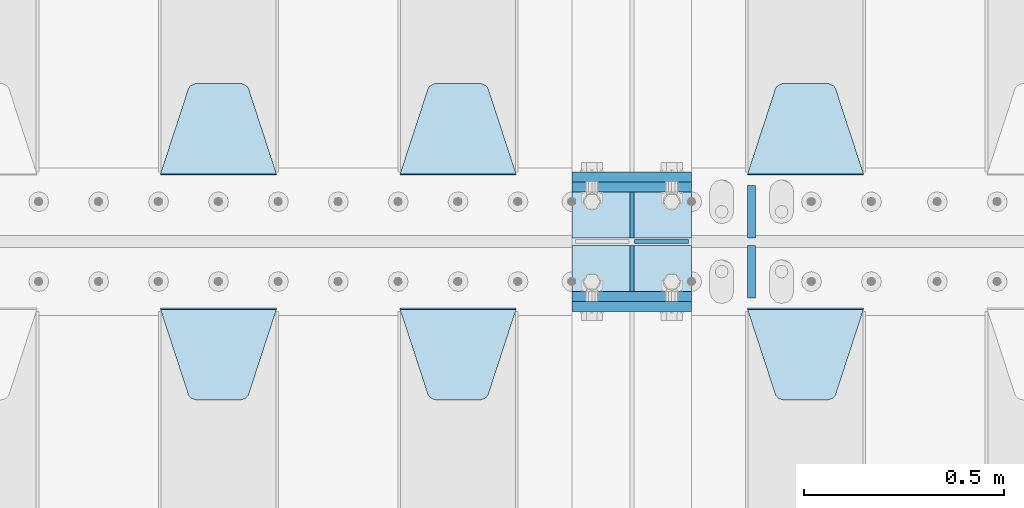
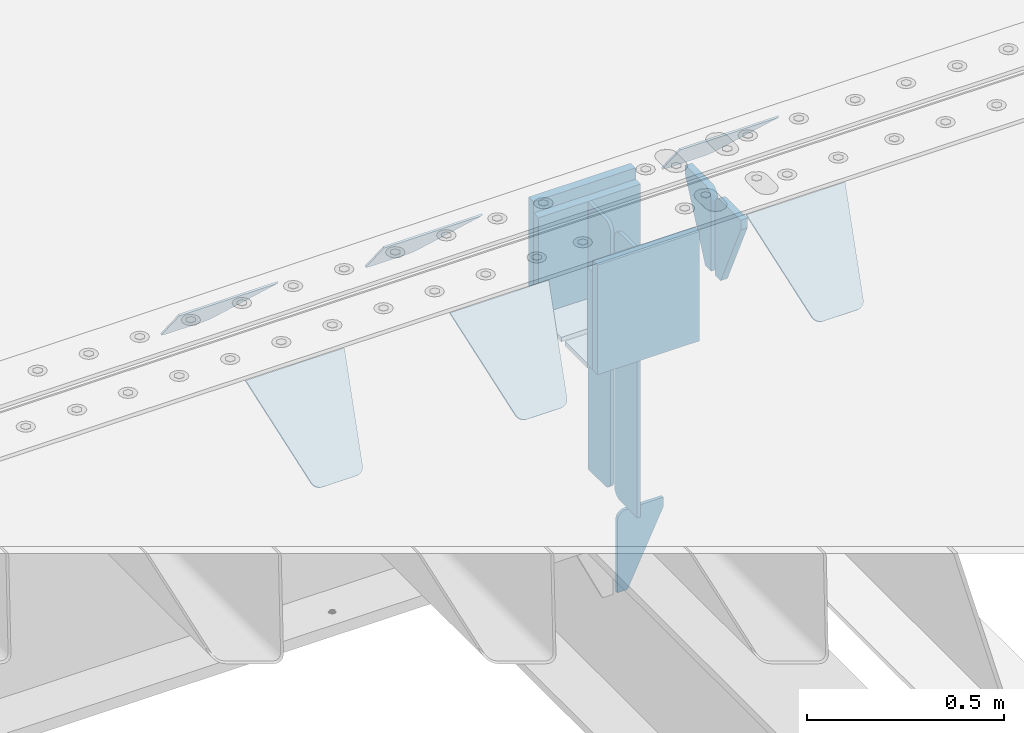
# One storey, part 228 of 270: 19 plates.
"""IFC2X3 building model written with IfcOpenShell, lengths in millimetres."""

from ifc_helpers import new_model, si_unit, frame, origin_with_axes, place, context, subcontext, project, spatial, faceted_brep, material, type_object, element, save


model = new_model("IFC2X3")

# Units and contexts
model_context = context("Model", 3, precision=1e-05, world=origin_with_axes())
body_context = subcontext(model_context, "Body", "Model", "MODEL_VIEW")
ifc_project = project(units=[si_unit("LENGTHUNIT", "METRE", prefix="MILLI"), si_unit("AREAUNIT", "SQUARE_METRE"), si_unit("VOLUMEUNIT", "CUBIC_METRE"), si_unit("MASSUNIT", "GRAM", prefix="KILO"), si_unit("TIMEUNIT", "SECOND"), si_unit("PLANEANGLEUNIT", "RADIAN"), si_unit("SOLIDANGLEUNIT", "STERADIAN"), si_unit("THERMODYNAMICTEMPERATUREUNIT", "DEGREE_CELSIUS"), si_unit("LUMINOUSINTENSITYUNIT", "LUMEN")], contexts=[model_context])

# Site, building, storey
site_placement = place(None, origin_with_axes())
site = spatial("IfcSite", under=ifc_project, at=site_placement, CompositionType="ELEMENT")
building_placement = place(site_placement, origin_with_axes())
building = spatial("IfcBuilding", under=site, at=building_placement, Name="Standard", CompositionType="ELEMENT")
storey_placement = place(building_placement, origin_with_axes())
storey = spatial("IfcBuildingStorey", under=building, at=storey_placement, Name="Undefined", CompositionType="ELEMENT", Elevation=0.0)

# Plates
ifc_material = material(Name="STEEL/S355N")
plate_type_1 = type_object("IfcPlateType", PredefinedType="NOTDEFINED")
for number, where, z_axis, x_axis in (
    (1, (13885.0, -17837.5, -340.000000000044), (0.0, 0.0, 1.0), (1.0, 0.0, 0.0)),
    (2, (13885.0, -18162.5, -340.000000000044), (0.0, 0.0, 1.0), (1.0, 0.0, 0.0)),
):
    element("IfcPlate", number, at=place(storey_placement, frame(where, z_axis=z_axis, x_axis=x_axis)), inside=storey, type_object=plate_type_1, material=ifc_material, context=body_context, shape_type="Brep", body=[
        faceted_brep([(0.0, -12.5, 0.0), (9.27684595808387e-10, -12.5, 340.0), (9.27684595808387e-10, 12.5, 340.0), (0.0, 12.5, 0.0), (300.0, -12.5, 340.0), (300.0, 12.5, 340.0), (300.0, -12.5, 0.0), (300.0, 12.5, 0.0)], [[[0, 1, 2, 3]], [[1, 4, 5, 2]], [[4, 6, 7, 5]], [[6, 0, 3, 7]], [[5, 7, 3, 2]], [[6, 4, 1, 0]]]),
    ])
for number, where, z_axis, x_axis in (
    (3, (13885.0, -17862.5, -340.0), (0.0, 0.0, 1.0), (1.0, 0.0, 0.0)),
    (4, (13885.0, -18137.5, -340.0), (0.0, 0.0, 1.0), (1.0, 0.0, 0.0)),
):
    element("IfcPlate", number, at=place(storey_placement, frame(where, z_axis=z_axis, x_axis=x_axis)), inside=storey, type_object=plate_type_1, material=ifc_material, context=body_context, shape_type="Brep", body=[
        faceted_brep([(0.0, -12.5, 0.0), (0.0, -12.5, 305.0), (0.0, 12.5, 305.0), (0.0, 12.5, 0.0), (300.0, -12.5, 305.0), (300.0, 12.5, 305.0), (300.0, -12.5, 0.0), (300.0, 12.5, 0.0)], [[[0, 1, 2, 3]], [[1, 4, 5, 2]], [[4, 6, 7, 5]], [[6, 0, 3, 7]], [[5, 7, 3, 2]], [[6, 4, 1, 0]]]),
    ])
plate_type_2 = type_object("IfcPlateType", PredefinedType="NOTDEFINED")
for number, where, z_axis, x_axis in (
    (5, (13885.0, -18009.25, -343.0), (0.0, -1.0, 0.0), (1.0, 0.0, 0.0)),
    (6, (13885.0, -17990.75, -343.0), (0.0, 1.0, 0.0), (1.0, 0.0, 0.0)),
):
    element("IfcPlate", number, at=place(storey_placement, frame(where, z_axis=z_axis, x_axis=x_axis)), inside=storey, type_object=plate_type_2, material=ifc_material, context=body_context, shape_type="Brep", body=[
        faceted_brep([(0.0, -7.0, 0.0), (0.0, -7.0, 115.75), (0.0, 7.0, 115.75), (0.0, 7.0, 0.0), (300.0, -7.0, 115.75), (300.0, 7.0, 115.75), (300.0, -7.0, 0.0), (300.0, 7.0, 0.0)], [[[0, 1, 2, 3]], [[1, 4, 5, 2]], [[4, 6, 7, 5]], [[6, 0, 3, 7]], [[5, 7, 3, 2]], [[6, 4, 1, 0]]]),
    ])
plate_type_3 = type_object("IfcPlateType", PredefinedType="NOTDEFINED")
plate_1_placement = place(storey_placement, frame((14035.0, -17990.75, -35.0), z_axis=(0.0, 0.0, -1.0), x_axis=(0.0, 1.0, 0.0)))
element("IfcPlate", 7, at=plate_1_placement, inside=storey, type_object=plate_type_3, material=ifc_material, context=body_context, shape_type="Brep", body=[
    faceted_brep([(0.0, -5.0, 30.0), (0.0, -5.0, 301.0), (0.0, 5.0, 301.0), (0.0, 5.0, 30.0), (115.75, -5.0, 301.0), (115.75, 5.0, 301.0), (115.75, -5.0, 0.0), (115.75, 5.0, 0.0), (30.0, -5.0, 0.0), (30.0, 5.0, 0.0), (24.7905546699913, -5.0, 0.455767409633758), (24.7905546699913, 5.0, 0.455767409633758), (19.7393957002314, -5.0, 1.80922137642275), (19.7393957002314, 5.0, 1.80922137642275), (15.0, -5.0, 4.01923788646684), (15.0, 5.0, 4.01923788646684), (10.7163717094045, -5.0, 7.01866670643066), (10.7163717094045, 5.0, 7.01866670643066), (7.01866670642994, -5.0, 10.7163717094038), (7.01866670642994, 5.0, 10.7163717094038), (4.01923788646673, -5.0, 15.0), (4.01923788646673, 5.0, 15.0), (1.80922137642119, -5.0, 19.7393957002299), (1.80922137642119, 5.0, 19.7393957002299), (0.455767409632244, -5.0, 24.7905546699921), (0.455767409632244, 5.0, 24.7905546699921)], [[[0, 1, 2, 3]], [[1, 4, 5, 2]], [[4, 6, 7, 5]], [[6, 8, 9, 7]], [[8, 10, 11, 9]], [[10, 12, 13, 11]], [[12, 14, 15, 13]], [[14, 16, 17, 15]], [[16, 18, 19, 17]], [[18, 20, 21, 19]], [[20, 22, 23, 21]], [[22, 24, 25, 23]], [[24, 0, 3, 25]], [[5, 7, 9, 11, 13, 15, 17, 19, 21, 23, 25, 3, 2]], [[24, 22, 20, 18, 16, 14, 12, 10, 8, 6, 4, 1, 0]]]),
])
for number, where, z_axis, x_axis in (
    (8, (14035.0, -18009.25, -350.0), (0.0, 0.0, -1.0), (0.0, -1.0, 0.0)),
    (9, (14035.0, -17990.75, -350.0), (0.0, 0.0, -1.0), (0.0, 1.0, 0.0)),
):
    element("IfcPlate", number, at=place(storey_placement, frame(where, z_axis=z_axis, x_axis=x_axis)), inside=storey, type_object=plate_type_3, material=ifc_material, context=body_context, shape_type="Brep", body=[
        faceted_brep([(0.0, -5.0, 0.0), (0.0, -5.0, 485.0), (0.0, 5.0, 485.0), (0.0, 5.0, 0.0), (0.455767409634063, -5.0, 490.209445330008), (0.455767409634063, 5.0, 490.209445330008), (1.80922137642301, -5.0, 495.26060429977), (1.80922137642301, 5.0, 495.26060429977), (4.01923788646673, -5.0, 500.0), (4.01923788646673, 5.0, 500.0), (7.01866670642994, -5.0, 504.283628290596), (7.01866670642994, 5.0, 504.283628290596), (10.7163717094045, -5.0, 507.981333293569), (10.7163717094045, 5.0, 507.981333293569), (15.0, -5.0, 510.980762113533), (15.0, 5.0, 510.980762113533), (19.7393957002296, -5.0, 513.190778623577), (19.7393957002296, 5.0, 513.190778623577), (24.7905546699913, -5.0, 514.544232590366), (24.7905546699913, 5.0, 514.544232590366), (30.0, -5.0, 515.0), (30.0, 5.0, 515.0), (115.75, -5.0, 515.0), (115.75, 5.0, 515.0), (115.75, -5.0, 0.0), (115.75, 5.0, 0.0)], [[[0, 1, 2, 3]], [[1, 4, 5, 2]], [[4, 6, 7, 5]], [[6, 8, 9, 7]], [[8, 10, 11, 9]], [[10, 12, 13, 11]], [[12, 14, 15, 13]], [[14, 16, 17, 15]], [[16, 18, 19, 17]], [[18, 20, 21, 19]], [[20, 22, 23, 21]], [[22, 24, 25, 23]], [[24, 0, 3, 25]], [[5, 7, 9, 11, 13, 15, 17, 19, 21, 23, 25, 3, 2]], [[24, 22, 20, 18, 16, 14, 12, 10, 8, 6, 4, 1, 0]]]),
    ])
plate_2_placement = place(storey_placement, frame((14035.0, -18009.25, -35.0), z_axis=(0.0, 0.0, -1.0), x_axis=(0.0, -1.0, 0.0)))
element("IfcPlate", 10, at=plate_2_placement, inside=storey, type_object=plate_type_3, material=ifc_material, context=body_context, shape_type="Brep", body=[
    faceted_brep([(0.0, -5.0, 30.0), (0.0, -5.0, 301.0), (0.0, 5.0, 301.0), (0.0, 5.0, 30.0), (115.75, -5.0, 301.0), (115.75, 5.0, 301.0), (115.75, -5.0, 0.0), (115.75, 5.0, 0.0), (30.0, -5.0, 0.0), (30.0, 5.0, 0.0), (24.7905546699913, -5.0, 0.455767409633758), (24.7905546699913, 5.0, 0.455767409633758), (19.7393957002314, -5.0, 1.80922137642275), (19.7393957002314, 5.0, 1.80922137642275), (15.0, -5.0, 4.01923788646684), (15.0, 5.0, 4.01923788646684), (10.7163717094045, -5.0, 7.01866670643066), (10.7163717094045, 5.0, 7.01866670643066), (7.01866670642994, -5.0, 10.7163717094038), (7.01866670642994, 5.0, 10.7163717094038), (4.01923788646673, -5.0, 15.0), (4.01923788646673, 5.0, 15.0), (1.80922137642119, -5.0, 19.7393957002299), (1.80922137642119, 5.0, 19.7393957002299), (0.455767409632244, -5.0, 24.7905546699921), (0.455767409632244, 5.0, 24.7905546699921)], [[[0, 1, 2, 3]], [[1, 4, 5, 2]], [[4, 6, 7, 5]], [[6, 8, 9, 7]], [[8, 10, 11, 9]], [[10, 12, 13, 11]], [[12, 14, 15, 13]], [[14, 16, 17, 15]], [[16, 18, 19, 17]], [[18, 20, 21, 19]], [[20, 22, 23, 21]], [[22, 24, 25, 23]], [[24, 0, 3, 25]], [[5, 7, 9, 11, 13, 15, 17, 19, 21, 23, 25, 3, 2]], [[24, 22, 20, 18, 16, 14, 12, 10, 8, 6, 4, 1, 0]]]),
])
plate_type_4 = type_object("IfcPlateType", PredefinedType="NOTDEFINED")
plate_3_placement = place(storey_placement, frame((14041.5000000039, -18000.0000000457, -925.000018238937), z_axis=(0.0, 0.0, -1.0), x_axis=(1.0, 0.0, 0.0)))
element("IfcPlate", 11, at=plate_3_placement, inside=storey, type_object=plate_type_4, material=ifc_material, context=body_context, shape_type="Brep", body=[
    faceted_brep([(0.0, -5.0, 27.0), (0.0, -5.0, 250.0), (0.0, 5.0, 250.0), (0.0, 5.0, 27.0), (30.0, -5.0, 250.0), (30.0, 5.0, 250.0), (135.0, -5.0, 30.0), (135.0, 5.0, 30.0), (135.0, -5.0, 0.0), (135.0, 5.0, 0.0), (27.0, -5.0, 0.0), (27.0, 5.0, 0.0), (22.3114992029932, -5.0, 0.410190668670339), (22.3114992029932, 5.0, 0.410190668670339), (17.7654561302061, -5.0, 1.62829923878053), (17.7654561302061, 5.0, 1.62829923878053), (13.5, -5.0, 3.6173140978201), (13.5, 5.0, 3.6173140978201), (9.64473453846404, -5.0, 6.31680003578754), (9.64473453846404, 5.0, 6.31680003578754), (6.31680003578731, -5.0, 9.64473453846347), (6.31680003578731, 5.0, 9.64473453846347), (3.61731409782078, -5.0, 13.5), (3.61731409782078, 5.0, 13.5), (1.62829923878053, -5.0, 17.765456130207), (1.62829923878053, 5.0, 17.765456130207), (0.410190668670111, -5.0, 22.3114992029929), (0.410190668670111, 5.0, 22.3114992029929)], [[[0, 1, 2, 3]], [[1, 4, 5, 2]], [[4, 6, 7, 5]], [[6, 8, 9, 7]], [[8, 10, 11, 9]], [[10, 12, 13, 11]], [[12, 14, 15, 13]], [[14, 16, 17, 15]], [[16, 18, 19, 17]], [[18, 20, 21, 19]], [[20, 22, 23, 21]], [[22, 24, 25, 23]], [[24, 26, 27, 25]], [[26, 0, 3, 27]], [[5, 7, 9, 11, 13, 15, 17, 19, 21, 23, 25, 27, 3, 2]], [[26, 24, 22, 20, 18, 16, 14, 12, 10, 8, 6, 4, 1, 0]]]),
])
plate_type_5 = type_object("IfcPlateType", PredefinedType="NOTDEFINED")
plate_4_placement = place(storey_placement, frame((14615.0, -17831.767766953, -1.76776695296758), z_axis=(0.0, 0.707106781186547, -0.707106781186548), x_axis=(-1.0, 0.0, 0.0)))
element("IfcPlate", 12, at=plate_4_placement, inside=storey, type_object=plate_type_5, material=ifc_material, context=body_context, shape_type="Brep", body=[
    faceted_brep([(0.0, -2.5, 0.0), (69.345504679477, -2.5, 300.171731424831), (69.345504679477, 2.5, 300.171731424831), (0.0, 2.5, 0.0), (70.9274061199576, -2.5, 304.8974424154), (70.9274061199576, 2.5, 304.8974424154), (73.3818627772307, -2.49999999999818, 309.234538108527), (73.3818627772307, 2.50000000000182, 309.234538108527), (76.6187032999551, -2.5, 313.023683126103), (76.6187032999551, 2.5, 313.023683126103), (80.5190132704993, -2.5, 316.125672595372), (80.5190132704993, 2.50000000000182, 316.125672595372), (84.9395038596849, -2.49999999999818, 318.426546230476), (84.9395038596849, 2.5, 318.426546230476), (89.7177759439219, -2.49999999999818, 319.841774983275), (89.7177759439219, 2.50000000000182, 319.841774983275), (94.678286292652, -2.5, 320.319366455078), (94.678286292652, 2.5, 320.319366455078), (195.321713707348, -2.5, 320.319366455078), (195.321713707348, 2.5, 320.319366455078), (200.282224056078, -2.49999999999818, 319.841774983275), (200.282224056078, 2.50000000000182, 319.841774983275), (205.060496140315, -2.5, 318.426546230476), (205.060496140315, 2.5, 318.426546230476), (209.480986729501, -2.5, 316.12567259537), (209.480986729501, 2.50000000000182, 316.12567259537), (213.381296700045, -2.5, 313.023683126103), (213.381296700045, 2.5, 313.023683126103), (216.618137222769, -2.49999999999818, 309.234538108525), (216.618137222769, 2.50000000000182, 309.234538108527), (219.072593880042, -2.49999999999818, 304.897442415398), (219.072593880042, 2.50000000000182, 304.897442415397), (220.654495320523, -2.5, 300.171731424831), (220.654495320523, 2.5, 300.171731424831), (290.0, -2.49999999999818, 0.0), (290.0, 2.5, 0.0)], [[[0, 1, 2, 3]], [[1, 4, 5, 2]], [[4, 6, 7, 5]], [[6, 8, 9, 7]], [[8, 10, 11, 9]], [[10, 12, 13, 11]], [[12, 14, 15, 13]], [[14, 16, 17, 15]], [[16, 18, 19, 17]], [[18, 20, 21, 19]], [[20, 22, 23, 21]], [[22, 24, 25, 23]], [[24, 26, 27, 25]], [[26, 28, 29, 27]], [[28, 30, 31, 29]], [[30, 32, 33, 31]], [[32, 34, 35, 33]], [[34, 0, 3, 35]], [[5, 7, 9, 11, 13, 15, 17, 19, 21, 23, 25, 27, 29, 31, 33, 35, 3, 2]], [[34, 32, 30, 28, 26, 24, 22, 20, 18, 16, 14, 12, 10, 8, 6, 4, 1, 0]]]),
])
plate_5_placement = place(storey_placement, frame((13745.0, -17831.767766953, -1.76776695296758), z_axis=(0.0, 0.707106781186547, -0.707106781186548), x_axis=(-1.0, 0.0, 0.0)))
element("IfcPlate", 13, at=plate_5_placement, inside=storey, type_object=plate_type_5, material=ifc_material, context=body_context, shape_type="Brep", body=[
    faceted_brep([(0.0, -2.5, 0.0), (69.345504679477, -2.5, 300.171731424831), (69.345504679477, 2.5, 300.171731424831), (0.0, 2.5, 0.0), (70.9274061199576, -2.5, 304.8974424154), (70.9274061199576, 2.5, 304.8974424154), (73.3818627772307, -2.49999999999818, 309.234538108527), (73.3818627772307, 2.50000000000182, 309.234538108527), (76.6187032999551, -2.5, 313.023683126103), (76.6187032999551, 2.5, 313.023683126103), (80.5190132704993, -2.5, 316.125672595372), (80.5190132704993, 2.50000000000182, 316.125672595372), (84.9395038596849, -2.49999999999818, 318.426546230476), (84.9395038596849, 2.5, 318.426546230476), (89.7177759439219, -2.49999999999818, 319.841774983275), (89.7177759439219, 2.50000000000182, 319.841774983275), (94.678286292652, -2.5, 320.319366455078), (94.678286292652, 2.5, 320.319366455078), (195.321713707348, -2.5, 320.319366455078), (195.321713707348, 2.5, 320.319366455078), (200.282224056078, -2.49999999999818, 319.841774983275), (200.282224056078, 2.50000000000182, 319.841774983275), (205.060496140315, -2.5, 318.426546230476), (205.060496140315, 2.5, 318.426546230476), (209.480986729501, -2.5, 316.12567259537), (209.480986729501, 2.50000000000182, 316.12567259537), (213.381296700045, -2.5, 313.023683126103), (213.381296700045, 2.5, 313.023683126103), (216.618137222769, -2.49999999999818, 309.234538108525), (216.618137222769, 2.50000000000182, 309.234538108527), (219.072593880042, -2.49999999999818, 304.897442415398), (219.072593880042, 2.50000000000182, 304.897442415397), (220.654495320523, -2.5, 300.171731424831), (220.654495320523, 2.5, 300.171731424831), (290.0, -2.49999999999818, 0.0), (290.0, 2.5, 0.0)], [[[0, 1, 2, 3]], [[1, 4, 5, 2]], [[4, 6, 7, 5]], [[6, 8, 9, 7]], [[8, 10, 11, 9]], [[10, 12, 13, 11]], [[12, 14, 15, 13]], [[14, 16, 17, 15]], [[16, 18, 19, 17]], [[18, 20, 21, 19]], [[20, 22, 23, 21]], [[22, 24, 25, 23]], [[24, 26, 27, 25]], [[26, 28, 29, 27]], [[28, 30, 31, 29]], [[30, 32, 33, 31]], [[32, 34, 35, 33]], [[34, 0, 3, 35]], [[5, 7, 9, 11, 13, 15, 17, 19, 21, 23, 25, 27, 29, 31, 33, 35, 3, 2]], [[34, 32, 30, 28, 26, 24, 22, 20, 18, 16, 14, 12, 10, 8, 6, 4, 1, 0]]]),
])
plate_6_placement = place(storey_placement, frame((13145.0, -17831.767766953, -1.76776695296758), z_axis=(0.0, 0.707106781186547, -0.707106781186548), x_axis=(-1.0, 0.0, 0.0)))
element("IfcPlate", 14, at=plate_6_placement, inside=storey, type_object=plate_type_5, material=ifc_material, context=body_context, shape_type="Brep", body=[
    faceted_brep([(0.0, -2.5, 0.0), (69.345504679477, -2.5, 300.171731424831), (69.345504679477, 2.5, 300.171731424831), (0.0, 2.5, 0.0), (70.9274061199576, -2.5, 304.8974424154), (70.9274061199576, 2.5, 304.8974424154), (73.3818627772307, -2.49999999999818, 309.234538108527), (73.3818627772307, 2.50000000000182, 309.234538108527), (76.6187032999551, -2.5, 313.023683126103), (76.6187032999551, 2.5, 313.023683126103), (80.5190132704993, -2.5, 316.125672595372), (80.5190132704993, 2.50000000000182, 316.125672595372), (84.9395038596849, -2.49999999999818, 318.426546230476), (84.9395038596849, 2.5, 318.426546230476), (89.7177759439219, -2.49999999999818, 319.841774983275), (89.7177759439219, 2.50000000000182, 319.841774983275), (94.678286292652, -2.5, 320.319366455078), (94.678286292652, 2.5, 320.319366455078), (195.321713707348, -2.5, 320.319366455078), (195.321713707348, 2.5, 320.319366455078), (200.282224056078, -2.49999999999818, 319.841774983275), (200.282224056078, 2.50000000000182, 319.841774983275), (205.060496140315, -2.5, 318.426546230476), (205.060496140315, 2.5, 318.426546230476), (209.480986729501, -2.5, 316.12567259537), (209.480986729501, 2.50000000000182, 316.12567259537), (213.381296700045, -2.5, 313.023683126103), (213.381296700045, 2.5, 313.023683126103), (216.618137222769, -2.49999999999818, 309.234538108525), (216.618137222769, 2.50000000000182, 309.234538108527), (219.072593880042, -2.49999999999818, 304.897442415398), (219.072593880042, 2.50000000000182, 304.897442415397), (220.654495320523, -2.5, 300.171731424831), (220.654495320523, 2.5, 300.171731424831), (290.0, -2.49999999999818, 0.0), (290.0, 2.5, 0.0)], [[[0, 1, 2, 3]], [[1, 4, 5, 2]], [[4, 6, 7, 5]], [[6, 8, 9, 7]], [[8, 10, 11, 9]], [[10, 12, 13, 11]], [[12, 14, 15, 13]], [[14, 16, 17, 15]], [[16, 18, 19, 17]], [[18, 20, 21, 19]], [[20, 22, 23, 21]], [[22, 24, 25, 23]], [[24, 26, 27, 25]], [[26, 28, 29, 27]], [[28, 30, 31, 29]], [[30, 32, 33, 31]], [[32, 34, 35, 33]], [[34, 0, 3, 35]], [[5, 7, 9, 11, 13, 15, 17, 19, 21, 23, 25, 27, 29, 31, 33, 35, 3, 2]], [[34, 32, 30, 28, 26, 24, 22, 20, 18, 16, 14, 12, 10, 8, 6, 4, 1, 0]]]),
])
plate_7_placement = place(storey_placement, frame((14325.0, -18168.232233044, -1.76776695296576), z_axis=(0.0, -0.707106781186548, -0.707106781186547), x_axis=(1.0, 0.0, 0.0)))
element("IfcPlate", 15, at=plate_7_placement, inside=storey, type_object=plate_type_5, material=ifc_material, context=body_context, shape_type="Brep", body=[
    faceted_brep([(0.0, -2.5, 0.0), (69.345504679477, -2.5, 300.171731424831), (69.345504679477, 2.5, 300.171731424831), (0.0, 2.5, 0.0), (70.9274061199576, -2.5, 304.8974424154), (70.9274061199576, 2.5, 304.8974424154), (73.3818627772307, -2.49999999999818, 309.234538108527), (73.3818627772307, 2.50000000000182, 309.234538108527), (76.6187032999551, -2.5, 313.023683126103), (76.6187032999551, 2.5, 313.023683126103), (80.5190132704993, -2.5, 316.125672595372), (80.5190132704993, 2.50000000000182, 316.125672595372), (84.9395038596849, -2.49999999999818, 318.426546230476), (84.9395038596849, 2.5, 318.426546230476), (89.7177759439219, -2.49999999999818, 319.841774983275), (89.7177759439219, 2.50000000000182, 319.841774983275), (94.678286292652, -2.5, 320.319366455078), (94.678286292652, 2.5, 320.319366455078), (195.321713707348, -2.5, 320.319366455078), (195.321713707348, 2.5, 320.319366455078), (200.282224056078, -2.49999999999818, 319.841774983275), (200.282224056078, 2.50000000000182, 319.841774983275), (205.060496140315, -2.5, 318.426546230476), (205.060496140315, 2.5, 318.426546230476), (209.480986729501, -2.5, 316.12567259537), (209.480986729501, 2.50000000000182, 316.12567259537), (213.381296700045, -2.5, 313.023683126103), (213.381296700045, 2.5, 313.023683126103), (216.618137222769, -2.49999999999818, 309.234538108525), (216.618137222769, 2.50000000000182, 309.234538108527), (219.072593880042, -2.49999999999818, 304.897442415398), (219.072593880042, 2.50000000000182, 304.897442415397), (220.654495320523, -2.5, 300.171731424831), (220.654495320523, 2.5, 300.171731424831), (290.0, -2.49999999999818, 0.0), (290.0, 2.5, 0.0)], [[[0, 1, 2, 3]], [[1, 4, 5, 2]], [[4, 6, 7, 5]], [[6, 8, 9, 7]], [[8, 10, 11, 9]], [[10, 12, 13, 11]], [[12, 14, 15, 13]], [[14, 16, 17, 15]], [[16, 18, 19, 17]], [[18, 20, 21, 19]], [[20, 22, 23, 21]], [[22, 24, 25, 23]], [[24, 26, 27, 25]], [[26, 28, 29, 27]], [[28, 30, 31, 29]], [[30, 32, 33, 31]], [[32, 34, 35, 33]], [[34, 0, 3, 35]], [[5, 7, 9, 11, 13, 15, 17, 19, 21, 23, 25, 27, 29, 31, 33, 35, 3, 2]], [[34, 32, 30, 28, 26, 24, 22, 20, 18, 16, 14, 12, 10, 8, 6, 4, 1, 0]]]),
])
plate_8_placement = place(storey_placement, frame((13455.0, -18168.232233044, -1.76776695296576), z_axis=(0.0, -0.707106781186548, -0.707106781186547), x_axis=(1.0, 0.0, 0.0)))
element("IfcPlate", 16, at=plate_8_placement, inside=storey, type_object=plate_type_5, material=ifc_material, context=body_context, shape_type="Brep", body=[
    faceted_brep([(0.0, -2.5, 0.0), (69.345504679477, -2.5, 300.171731424831), (69.345504679477, 2.5, 300.171731424831), (0.0, 2.5, 0.0), (70.9274061199576, -2.5, 304.8974424154), (70.9274061199576, 2.5, 304.8974424154), (73.3818627772307, -2.49999999999818, 309.234538108527), (73.3818627772307, 2.50000000000182, 309.234538108527), (76.6187032999551, -2.5, 313.023683126103), (76.6187032999551, 2.5, 313.023683126103), (80.5190132704993, -2.5, 316.125672595372), (80.5190132704993, 2.50000000000182, 316.125672595372), (84.9395038596849, -2.49999999999818, 318.426546230476), (84.9395038596849, 2.5, 318.426546230476), (89.7177759439219, -2.49999999999818, 319.841774983275), (89.7177759439219, 2.50000000000182, 319.841774983275), (94.678286292652, -2.5, 320.319366455078), (94.678286292652, 2.5, 320.319366455078), (195.321713707348, -2.5, 320.319366455078), (195.321713707348, 2.5, 320.319366455078), (200.282224056078, -2.49999999999818, 319.841774983275), (200.282224056078, 2.50000000000182, 319.841774983275), (205.060496140315, -2.5, 318.426546230476), (205.060496140315, 2.5, 318.426546230476), (209.480986729501, -2.5, 316.12567259537), (209.480986729501, 2.50000000000182, 316.12567259537), (213.381296700045, -2.5, 313.023683126103), (213.381296700045, 2.5, 313.023683126103), (216.618137222769, -2.49999999999818, 309.234538108525), (216.618137222769, 2.50000000000182, 309.234538108527), (219.072593880042, -2.49999999999818, 304.897442415398), (219.072593880042, 2.50000000000182, 304.897442415397), (220.654495320523, -2.5, 300.171731424831), (220.654495320523, 2.5, 300.171731424831), (290.0, -2.49999999999818, 0.0), (290.0, 2.5, 0.0)], [[[0, 1, 2, 3]], [[1, 4, 5, 2]], [[4, 6, 7, 5]], [[6, 8, 9, 7]], [[8, 10, 11, 9]], [[10, 12, 13, 11]], [[12, 14, 15, 13]], [[14, 16, 17, 15]], [[16, 18, 19, 17]], [[18, 20, 21, 19]], [[20, 22, 23, 21]], [[22, 24, 25, 23]], [[24, 26, 27, 25]], [[26, 28, 29, 27]], [[28, 30, 31, 29]], [[30, 32, 33, 31]], [[32, 34, 35, 33]], [[34, 0, 3, 35]], [[5, 7, 9, 11, 13, 15, 17, 19, 21, 23, 25, 27, 29, 31, 33, 35, 3, 2]], [[34, 32, 30, 28, 26, 24, 22, 20, 18, 16, 14, 12, 10, 8, 6, 4, 1, 0]]]),
])
plate_9_placement = place(storey_placement, frame((12855.0, -18168.232233044, -1.76776695296576), z_axis=(0.0, -0.707106781186548, -0.707106781186547), x_axis=(1.0, 0.0, 0.0)))
element("IfcPlate", 17, at=plate_9_placement, inside=storey, type_object=plate_type_5, material=ifc_material, context=body_context, shape_type="Brep", body=[
    faceted_brep([(0.0, -2.5, 0.0), (69.345504679477, -2.5, 300.171731424831), (69.345504679477, 2.5, 300.171731424831), (0.0, 2.5, 0.0), (70.9274061199576, -2.5, 304.8974424154), (70.9274061199576, 2.5, 304.8974424154), (73.3818627772307, -2.49999999999818, 309.234538108527), (73.3818627772307, 2.50000000000182, 309.234538108527), (76.6187032999551, -2.5, 313.023683126103), (76.6187032999551, 2.5, 313.023683126103), (80.5190132704993, -2.5, 316.125672595372), (80.5190132704993, 2.50000000000182, 316.125672595372), (84.9395038596849, -2.49999999999818, 318.426546230476), (84.9395038596849, 2.5, 318.426546230476), (89.7177759439219, -2.49999999999818, 319.841774983275), (89.7177759439219, 2.50000000000182, 319.841774983275), (94.678286292652, -2.5, 320.319366455078), (94.678286292652, 2.5, 320.319366455078), (195.321713707348, -2.5, 320.319366455078), (195.321713707348, 2.5, 320.319366455078), (200.282224056078, -2.49999999999818, 319.841774983275), (200.282224056078, 2.50000000000182, 319.841774983275), (205.060496140315, -2.5, 318.426546230476), (205.060496140315, 2.5, 318.426546230476), (209.480986729501, -2.5, 316.12567259537), (209.480986729501, 2.50000000000182, 316.12567259537), (213.381296700045, -2.5, 313.023683126103), (213.381296700045, 2.5, 313.023683126103), (216.618137222769, -2.49999999999818, 309.234538108525), (216.618137222769, 2.50000000000182, 309.234538108527), (219.072593880042, -2.49999999999818, 304.897442415398), (219.072593880042, 2.50000000000182, 304.897442415397), (220.654495320523, -2.5, 300.171731424831), (220.654495320523, 2.5, 300.171731424831), (290.0, -2.49999999999818, 0.0), (290.0, 2.5, 0.0)], [[[0, 1, 2, 3]], [[1, 4, 5, 2]], [[4, 6, 7, 5]], [[6, 8, 9, 7]], [[8, 10, 11, 9]], [[10, 12, 13, 11]], [[12, 14, 15, 13]], [[14, 16, 17, 15]], [[16, 18, 19, 17]], [[18, 20, 21, 19]], [[20, 22, 23, 21]], [[22, 24, 25, 23]], [[24, 26, 27, 25]], [[26, 28, 29, 27]], [[28, 30, 31, 29]], [[30, 32, 33, 31]], [[32, 34, 35, 33]], [[34, 0, 3, 35]], [[5, 7, 9, 11, 13, 15, 17, 19, 21, 23, 25, 27, 29, 31, 33, 35, 3, 2]], [[34, 32, 30, 28, 26, 24, 22, 20, 18, 16, 14, 12, 10, 8, 6, 4, 1, 0]]]),
])
plate_type_6 = type_object("IfcPlateType", PredefinedType="NOTDEFINED")
for number, where, z_axis, x_axis in (
    (18, (14335.0, -17858.75, -35.0), (0.0, 0.0, -1.0), (0.0, -1.0, 0.0)),
    (19, (14335.0, -18141.25, -35.0), (0.0, 0.0, -1.0), (0.0, 1.0, 0.0)),
):
    element("IfcPlate", number, at=place(storey_placement, frame(where, z_axis=z_axis, x_axis=x_axis)), inside=storey, type_object=plate_type_6, material=ifc_material, context=body_context, shape_type="Brep", body=[
        faceted_brep([(0.0, -10.0, 0.0), (0.0, -10.0, 30.0), (0.0, 10.0, 30.0), (0.0, 10.0, 0.0), (102.0, -10.0, 250.0), (102.0, 10.0, 250.0), (132.0, -10.0, 250.0), (132.0, 10.0, 250.0), (132.0, -10.0, 30.0), (132.0, 10.0, 30.0), (131.544232590368, -10.0, 24.790554669992), (131.544232590368, 10.0, 24.790554669992), (130.190778623579, -10.0, 19.7393957002299), (130.190778623579, 10.0, 19.7393957002299), (127.980762113533, -10.0, 15.0), (127.980762113533, 10.0, 15.0), (124.98133329357, -10.0, 10.7163717094038), (124.98133329357, 10.0, 10.7163717094038), (121.283628290596, -10.0, 7.01866670643062), (121.283628290596, 10.0, 7.01866670643062), (117.0, -10.0, 4.01923788646684), (117.0, 10.0, 4.01923788646684), (112.260604299769, -10.0, 1.80922137642278), (112.260604299769, 10.0, 1.80922137642278), (107.209445330009, -10.0, 0.455767409633722), (107.209445330009, 10.0, 0.455767409633722), (102.0, -10.0, 0.0), (102.0, 10.0, 0.0)], [[[0, 1, 2, 3]], [[1, 4, 5, 2]], [[4, 6, 7, 5]], [[6, 8, 9, 7]], [[8, 10, 11, 9]], [[10, 12, 13, 11]], [[12, 14, 15, 13]], [[14, 16, 17, 15]], [[16, 18, 19, 17]], [[18, 20, 21, 19]], [[20, 22, 23, 21]], [[22, 24, 25, 23]], [[24, 26, 27, 25]], [[26, 0, 3, 27]], [[5, 7, 9, 11, 13, 15, 17, 19, 21, 23, 25, 27, 3, 2]], [[26, 24, 22, 20, 18, 16, 14, 12, 10, 8, 6, 4, 1, 0]]]),
    ])

save(model, "model.ifc")
